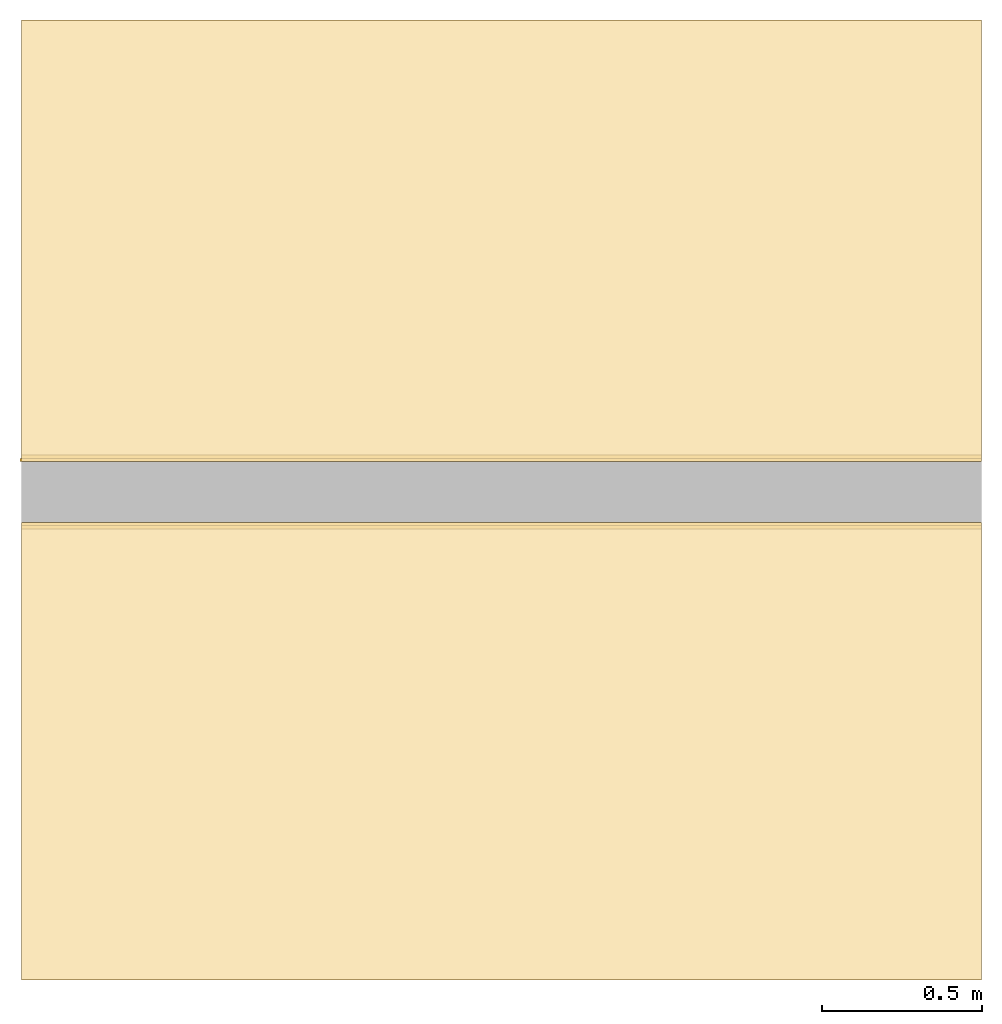
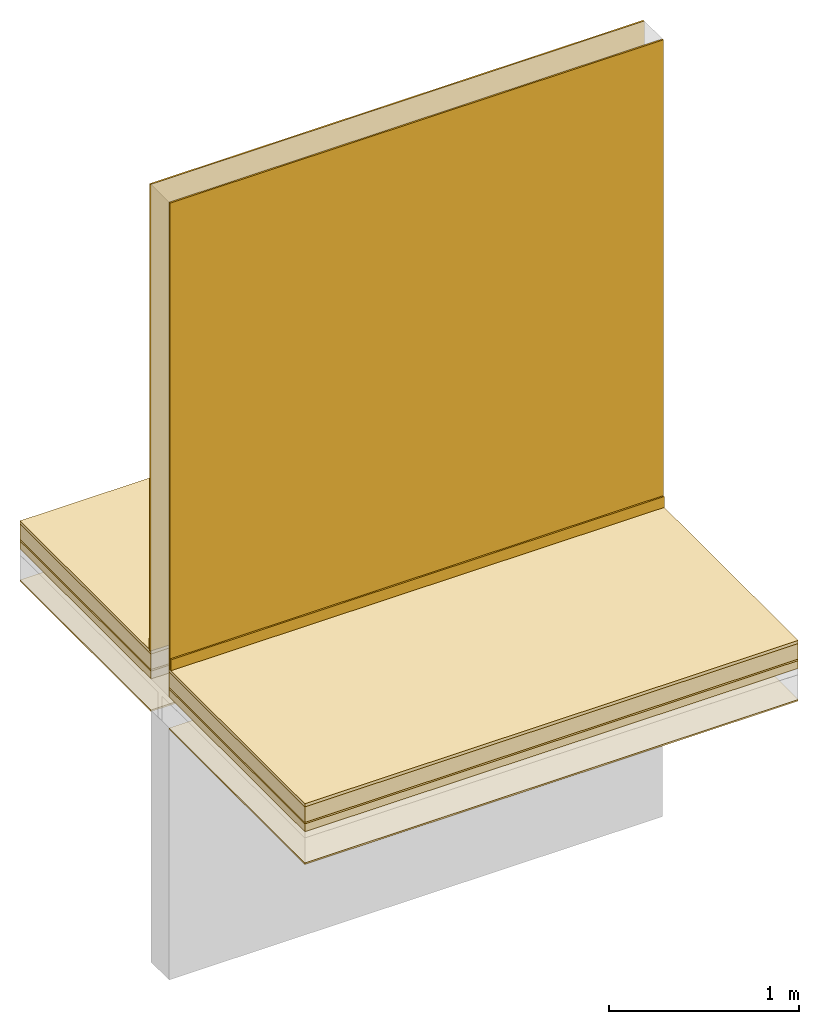
# One storey, part 2 of 2: 14 coverings.
"""IFC4 building model written with IfcOpenShell, lengths in centimetres."""

from ifc_helpers import new_model, si_unit, frame, origin_with_axes, place, context, subcontext, project, spatial, polygons, source, transform, mapped, element, save


model = new_model("IFC4")

# Units and contexts
model_context = context("Model", 3, precision=1e-05, world=origin_with_axes())
plan_context = context("Plan", 2, precision=1e-05, world=origin_with_axes())
body_context = subcontext(model_context, "Body", "Model", "MODEL_VIEW")
ifc_project = project(units=[si_unit("LENGTHUNIT", "METRE", prefix="CENTI"), si_unit("AREAUNIT", "SQUARE_METRE", prefix="CENTI"), si_unit("VOLUMEUNIT", "CUBIC_METRE", prefix="CENTI")], contexts=[model_context, plan_context])

# Site, building, storey
site_placement = place(None, frame((1288.70067596436, 2573.25820922852, 0.0), z_axis=(0.0, 0.0, 1.0), x_axis=(1.0, 0.0, 0.0)))
site = spatial("IfcSite", under=ifc_project, at=site_placement, CompositionType="ELEMENT")
building_placement = place(site_placement, origin_with_axes())
building = spatial("IfcBuilding", under=site, at=building_placement, Name="Default", CompositionType="ELEMENT")
storey_placement = place(building_placement, frame((0.0, 0.0, 1.9145924429198e-09), z_axis=(0.0, 0.0, 1.0), x_axis=(1.0, 0.0, 0.0)))
storey = spatial("IfcBuildingStorey", under=building, at=storey_placement, Name="0", CompositionType="ELEMENT")

# Coverings
shared_shape_1 = source(origin_with_axes(), body_context, "Body", "Tessellation", [
    polygons([(485.905364990234, 254.556915283203, -18.0), (485.905364990234, 254.556915283203, -13.0), (185.905349731445, 254.556915283203, -18.0), (185.905349731445, 254.556915283203, -13.0), (185.905349731445, 111.556922912598, -18.0), (185.905349731445, 111.556922912598, -13.0), (485.905364990234, 111.556922912598, -18.0), (485.905364990234, 111.556922912598, -13.0)], [[[8, 6, 5, 7]], [[2, 8, 7, 1]], [[1, 7, 5, 3]], [[6, 8, 2, 4]], [[4, 2, 1, 3]], [[6, 4, 3, 5]]]),
])
covering_1_placement = place(storey_placement, frame((9.5367431640625e-05, 0.00019073486328125, -1.9145924429198e-09), z_axis=(0.0, 0.0, 1.0), x_axis=(1.0, 0.0, 0.0)))
element("IfcCovering", 1, at=covering_1_placement, inside=storey, Name="Isolation - isolatie", PredefinedType="INSULATION", context=body_context, shape_type="MappedRepresentation", body=[
    mapped(shared_shape_1, transform((0.0, 0.0, 0.0), x_axis=(1.0, 0.0, 0.0), y_axis=(0.0, 1.0, 0.0), z_axis=(0.0, 0.0, 1.0), scale=1.0)),
])
shared_shape_2 = source(origin_with_axes(), body_context, "Body", "Tessellation", [
    polygons([(300.0, -0.5, 0.0), (300.0, -0.5, 300.0), (300.0, 0.5, 0.0), (300.0, 0.5, 300.0), (0.0, 0.5, 0.0), (0.0, 0.5, 300.0), (0.0, -0.5, 0.0), (0.0, -0.5, 300.0)], [[[8, 6, 5, 7]], [[2, 8, 7, 1]], [[1, 7, 5, 3]], [[6, 8, 2, 4]], [[4, 2, 1, 3]], [[6, 4, 3, 5]]]),
])
covering_2_placement = place(storey_placement, frame((485.905456542969, 254.057121276855, -1.9145924429198e-09), z_axis=(0.0, 0.0, 1.0), x_axis=(-1.0, -8.74227765734759e-08, 0.0)))
element("IfcCovering", 2, at=covering_2_placement, inside=storey, Name="Enduit", PredefinedType="CLADDING", context=body_context, shape_type="MappedRepresentation", body=[
    mapped(shared_shape_2, transform((0.0, 0.0, 0.0), x_axis=(1.0, 0.0, 0.0), y_axis=(0.0, 1.0, 0.0), z_axis=(0.0, 0.0, 1.0), scale=1.0)),
])
shared_shape_3 = source(origin_with_axes(), body_context, "Body", "Tessellation", [
    polygons([(485.905364990234, 254.556915283203, -39.0), (485.905364990234, 254.556915283203, -38.0), (185.905349731445, 254.556915283203, -39.0), (185.905349731445, 254.556915283203, -38.0), (185.905349731445, 111.556922912598, -39.0), (185.905349731445, 111.556922912598, -38.0), (485.905364990234, 111.556922912598, -39.0), (485.905364990234, 111.556922912598, -38.0)], [[[8, 6, 5, 7]], [[2, 8, 7, 1]], [[1, 7, 5, 3]], [[6, 8, 2, 4]], [[4, 2, 1, 3]], [[6, 4, 3, 5]]]),
])
covering_3_placement = place(storey_placement, frame((9.5367431640625e-05, 0.00019073486328125, -1.9145924429198e-09), z_axis=(0.0, 0.0, 1.0), x_axis=(1.0, 0.0, 0.0)))
element("IfcCovering", 3, at=covering_3_placement, inside=storey, Name="Enduit", PredefinedType="CEILING", context=body_context, shape_type="MappedRepresentation", body=[
    mapped(shared_shape_3, transform((0.0, 0.0, 0.0), x_axis=(1.0, 0.0, 0.0), y_axis=(0.0, 1.0, 0.0), z_axis=(0.0, 0.0, 1.0), scale=1.0)),
])
shared_shape_4 = source(origin_with_axes(), body_context, "Body", "Tessellation", [
    polygons([(485.905364990234, 411.556915283203, -18.0), (485.905364990234, 411.556915283203, -13.0), (185.905349731445, 411.556915283203, -18.0), (185.905349731445, 411.556915283203, -13.0), (185.905349731445, 273.556915283203, -18.0), (185.905349731445, 273.556915283203, -13.0), (485.905364990234, 273.556915283203, -18.0), (485.905364990234, 273.556915283203, -13.0)], [[[8, 6, 5, 7]], [[2, 8, 7, 1]], [[1, 7, 5, 3]], [[6, 8, 2, 4]], [[4, 2, 1, 3]], [[6, 4, 3, 5]]]),
])
covering_4_placement = place(storey_placement, frame((9.5367431640625e-05, 0.00019073486328125, -1.9145924429198e-09), z_axis=(0.0, 0.0, 1.0), x_axis=(1.0, 0.0, 0.0)))
element("IfcCovering", 4, at=covering_4_placement, inside=storey, Name="Isolation - isolatie", PredefinedType="INSULATION", context=body_context, shape_type="MappedRepresentation", body=[
    mapped(shared_shape_4, transform((0.0, 0.0, 0.0), x_axis=(1.0, 0.0, 0.0), y_axis=(0.0, 1.0, 0.0), z_axis=(0.0, 0.0, 1.0), scale=1.0)),
])
shared_shape_5 = source(origin_with_axes(), body_context, "Body", "Tessellation", [
    polygons([(300.5, -0.5, 0.0), (300.5, -0.5, 300.0), (300.5, 0.5, 0.0), (300.5, 0.5, 300.0), (0.0, 0.5, 0.0), (0.0, 0.5, 300.0), (0.0, -0.5, 0.0), (0.0, -0.5, 300.0)], [[[8, 6, 5, 7]], [[2, 8, 7, 1]], [[1, 7, 5, 3]], [[6, 8, 2, 4]], [[4, 2, 1, 3]], [[6, 4, 3, 5]]]),
])
covering_5_placement = place(storey_placement, frame((485.905456542969, 274.057006835938, -1.9145924429198e-09), z_axis=(0.0, 0.0, 1.0), x_axis=(-1.0, -8.74227765734759e-08, 0.0)))
element("IfcCovering", 5, at=covering_5_placement, inside=storey, Name="Enduit", PredefinedType="CLADDING", context=body_context, shape_type="MappedRepresentation", body=[
    mapped(shared_shape_5, transform((0.0, 0.0, 0.0), x_axis=(1.0, 0.0, 0.0), y_axis=(0.0, 1.0, 0.0), z_axis=(0.0, 0.0, 1.0), scale=1.0)),
])
shared_shape_6 = source(origin_with_axes(), body_context, "Body", "Tessellation", [
    polygons([(485.905364990234, 254.556915283203, -12.0), (485.905364990234, 254.556915283203, -2.0), (185.905349731445, 254.556915283203, -12.0), (185.905349731445, 254.556915283203, -2.0), (185.905349731445, 111.556922912598, -12.0), (185.905349731445, 111.556922912598, -2.0), (485.905364990234, 111.556922912598, -12.0), (485.905364990234, 111.556922912598, -2.0)], [[[8, 6, 5, 7]], [[2, 8, 7, 1]], [[1, 7, 5, 3]], [[6, 8, 2, 4]], [[4, 2, 1, 3]], [[6, 4, 3, 5]]]),
])
covering_6_placement = place(storey_placement, frame((9.5367431640625e-05, 0.00019073486328125, -1.9145924429198e-09), z_axis=(0.0, 0.0, 1.0), x_axis=(1.0, 0.0, 0.0)))
element("IfcCovering", 6, at=covering_6_placement, inside=storey, Name="Chape", PredefinedType="FLOORING", context=body_context, shape_type="MappedRepresentation", body=[
    mapped(shared_shape_6, transform((0.0, 0.0, 0.0), x_axis=(1.0, 0.0, 0.0), y_axis=(0.0, 1.0, 0.0), z_axis=(0.0, 0.0, 1.0), scale=1.0)),
])
shared_shape_7 = source(origin_with_axes(), body_context, "Body", "Tessellation", [
    polygons([(485.905364990234, 411.556915283203, -2.0), (485.905364990234, 411.556915283203, 0.0), (185.905349731445, 411.556915283203, -2.0), (185.905349731445, 411.556915283203, 0.0), (185.905349731445, 273.556915283203, -2.0), (185.905349731445, 273.556915283203, 0.0), (485.905364990234, 273.556915283203, -2.0), (485.905364990234, 273.556915283203, 0.0)], [[[8, 6, 5, 7]], [[2, 8, 7, 1]], [[1, 7, 5, 3]], [[6, 8, 2, 4]], [[4, 2, 1, 3]], [[6, 4, 3, 5]]]),
])
covering_7_placement = place(storey_placement, frame((9.5367431640625e-05, 0.00019073486328125, -1.9145924429198e-09), z_axis=(0.0, 0.0, 1.0), x_axis=(1.0, 0.0, 0.0)))
element("IfcCovering", 7, at=covering_7_placement, inside=storey, PredefinedType="FLOORING", context=body_context, shape_type="MappedRepresentation", body=[
    mapped(shared_shape_7, transform((0.0, 0.0, 0.0), x_axis=(1.0, 0.0, 0.0), y_axis=(0.0, 1.0, 0.0), z_axis=(0.0, 0.0, 1.0), scale=1.0)),
])
shared_shape_8 = source(origin_with_axes(), body_context, "Body", "Tessellation", [
    polygons([(185.905349731445, 252.556915283203, 0.0), (185.905349731445, 252.556915283203, 7.0), (485.905364990234, 252.556915283203, 0.0), (485.905364990234, 252.556915283203, 7.0), (485.905364990234, 253.556915283203, 0.0), (485.905364990234, 253.556915283203, 7.0), (185.905349731445, 253.556915283203, 0.0), (185.905349731445, 253.556915283203, 7.0)], [[[8, 6, 5, 7]], [[2, 8, 7, 1]], [[1, 7, 5, 3]], [[6, 8, 2, 4]], [[4, 2, 1, 3]], [[6, 4, 3, 5]]]),
])
covering_8_placement = place(storey_placement, frame((9.5367431640625e-05, 0.00019073486328125, -1.9145924429198e-09), z_axis=(0.0, 0.0, 1.0), x_axis=(1.0, 0.0, 0.0)))
element("IfcCovering", 8, at=covering_8_placement, inside=storey, PredefinedType="SKIRTINGBOARD", context=body_context, shape_type="MappedRepresentation", body=[
    mapped(shared_shape_8, transform((0.0, 0.0, 0.0), x_axis=(1.0, 0.0, 0.0), y_axis=(0.0, 1.0, 0.0), z_axis=(0.0, 0.0, 1.0), scale=1.0)),
])
shared_shape_9 = source(origin_with_axes(), body_context, "Body", "Tessellation", [
    polygons([(485.905364990234, 411.556915283203, -39.0), (485.905364990234, 411.556915283203, -38.0), (185.905349731445, 411.556915283203, -39.0), (185.905349731445, 411.556915283203, -38.0), (185.905349731445, 273.556915283203, -39.0), (185.905349731445, 273.556915283203, -38.0), (485.905364990234, 273.556915283203, -39.0), (485.905364990234, 273.556915283203, -38.0)], [[[8, 6, 5, 7]], [[2, 8, 7, 1]], [[1, 7, 5, 3]], [[6, 8, 2, 4]], [[4, 2, 1, 3]], [[6, 4, 3, 5]]]),
])
covering_9_placement = place(storey_placement, frame((9.5367431640625e-05, 0.00019073486328125, -1.9145924429198e-09), z_axis=(0.0, 0.0, 1.0), x_axis=(1.0, 0.0, 0.0)))
element("IfcCovering", 9, at=covering_9_placement, inside=storey, Name="Enduit", PredefinedType="CEILING", context=body_context, shape_type="MappedRepresentation", body=[
    mapped(shared_shape_9, transform((0.0, 0.0, 0.0), x_axis=(1.0, 0.0, 0.0), y_axis=(0.0, 1.0, 0.0), z_axis=(0.0, 0.0, 1.0), scale=1.0)),
])
shared_shape_10 = source(origin_with_axes(), body_context, "Body", "Tessellation", [
    polygons([(485.905364990234, 254.556915283203, -2.0), (485.905364990234, 254.556915283203, 0.0), (185.905349731445, 254.556915283203, -2.0), (185.905349731445, 254.556915283203, 0.0), (185.905349731445, 111.556922912598, -2.0), (185.905349731445, 111.556922912598, 0.0), (485.905364990234, 111.556922912598, -2.0), (485.905364990234, 111.556922912598, 0.0)], [[[8, 6, 5, 7]], [[2, 8, 7, 1]], [[1, 7, 5, 3]], [[6, 8, 2, 4]], [[4, 2, 1, 3]], [[6, 4, 3, 5]]]),
])
covering_10_placement = place(storey_placement, frame((9.5367431640625e-05, 0.00019073486328125, -1.9145924429198e-09), z_axis=(0.0, 0.0, 1.0), x_axis=(1.0, 0.0, 0.0)))
element("IfcCovering", 10, at=covering_10_placement, inside=storey, PredefinedType="FLOORING", context=body_context, shape_type="MappedRepresentation", body=[
    mapped(shared_shape_10, transform((0.0, 0.0, 0.0), x_axis=(1.0, 0.0, 0.0), y_axis=(0.0, 1.0, 0.0), z_axis=(0.0, 0.0, 1.0), scale=1.0)),
])
shared_shape_11 = source(origin_with_axes(), body_context, "Body", "Tessellation", [
    polygons([(485.905364990234, 411.556915283203, -12.0), (485.905364990234, 411.556915283203, -2.0), (185.905349731445, 411.556915283203, -12.0), (185.905349731445, 411.556915283203, -2.0), (185.905349731445, 273.556915283203, -12.0), (185.905349731445, 273.556915283203, -2.0), (485.905364990234, 273.556915283203, -12.0), (485.905364990234, 273.556915283203, -2.0)], [[[8, 6, 5, 7]], [[2, 8, 7, 1]], [[1, 7, 5, 3]], [[6, 8, 2, 4]], [[4, 2, 1, 3]], [[6, 4, 3, 5]]]),
])
covering_11_placement = place(storey_placement, frame((9.5367431640625e-05, 0.00019073486328125, -1.9145924429198e-09), z_axis=(0.0, 0.0, 1.0), x_axis=(1.0, 0.0, 0.0)))
element("IfcCovering", 11, at=covering_11_placement, inside=storey, Name="Chape", PredefinedType="FLOORING", context=body_context, shape_type="MappedRepresentation", body=[
    mapped(shared_shape_11, transform((0.0, 0.0, 0.0), x_axis=(1.0, 0.0, 0.0), y_axis=(0.0, 1.0, 0.0), z_axis=(0.0, 0.0, 1.0), scale=1.0)),
])
shared_shape_12 = source(origin_with_axes(), body_context, "Body", "Tessellation", [
    polygons([(185.905349731445, 411.556915283203, -13.0), (185.905349731445, 411.556915283203, -12.0), (185.905349731445, 273.556915283203, -13.0), (185.905349731445, 273.556915283203, -12.0), (485.905364990234, 273.556915283203, -13.0), (485.905364990234, 273.556915283203, -12.0), (485.905364990234, 411.556915283203, -13.0), (485.905364990234, 411.556915283203, -12.0)], [[[8, 6, 5, 7]], [[2, 8, 7, 1]], [[1, 7, 5, 3]], [[6, 8, 2, 4]], [[4, 2, 1, 3]], [[6, 4, 3, 5]]]),
])
covering_12_placement = place(storey_placement, frame((9.5367431640625e-05, 0.00019073486328125, -1.9145924429198e-09), z_axis=(0.0, 0.0, 1.0), x_axis=(1.0, 0.0, 0.0)))
element("IfcCovering", 12, at=covering_12_placement, inside=storey, Name="Pare-vapeur - folie", PredefinedType="MEMBRANE", context=body_context, shape_type="MappedRepresentation", body=[
    mapped(shared_shape_12, transform((0.0, 0.0, 0.0), x_axis=(1.0, 0.0, 0.0), y_axis=(0.0, 1.0, 0.0), z_axis=(0.0, 0.0, 1.0), scale=1.0)),
])
shared_shape_13 = source(origin_with_axes(), body_context, "Body", "Tessellation", [
    polygons([(185.905349731445, 274.556915283203, 0.0), (185.905349731445, 274.556915283203, 7.0), (485.905364990234, 274.556915283203, 0.0), (485.905364990234, 274.556915283203, 7.0), (485.905364990234, 275.556915283203, 0.0), (485.905364990234, 275.556915283203, 7.0), (185.905349731445, 275.556915283203, 0.0), (185.905349731445, 275.556915283203, 7.0)], [[[8, 6, 5, 7]], [[2, 8, 7, 1]], [[1, 7, 5, 3]], [[6, 8, 2, 4]], [[4, 2, 1, 3]], [[6, 4, 3, 5]]]),
])
covering_13_placement = place(storey_placement, frame((9.5367431640625e-05, 0.00019073486328125, -1.9145924429198e-09), z_axis=(0.0, 0.0, 1.0), x_axis=(1.0, 0.0, 0.0)))
element("IfcCovering", 13, at=covering_13_placement, inside=storey, PredefinedType="SKIRTINGBOARD", context=body_context, shape_type="MappedRepresentation", body=[
    mapped(shared_shape_13, transform((0.0, 0.0, 0.0), x_axis=(1.0, 0.0, 0.0), y_axis=(0.0, 1.0, 0.0), z_axis=(0.0, 0.0, 1.0), scale=1.0)),
])
shared_shape_14 = source(origin_with_axes(), body_context, "Body", "Tessellation", [
    polygons([(185.905349731445, 254.556915283203, -13.0), (185.905349731445, 254.556915283203, -12.0), (185.905349731445, 111.556922912598, -13.0), (185.905349731445, 111.556922912598, -12.0), (485.905364990234, 111.556922912598, -13.0), (485.905364990234, 111.556922912598, -12.0), (485.905364990234, 254.556915283203, -13.0), (485.905364990234, 254.556915283203, -12.0)], [[[8, 6, 5, 7]], [[2, 8, 7, 1]], [[1, 7, 5, 3]], [[6, 8, 2, 4]], [[4, 2, 1, 3]], [[6, 4, 3, 5]]]),
])
covering_14_placement = place(storey_placement, frame((9.5367431640625e-05, 0.00019073486328125, -1.9145924429198e-09), z_axis=(0.0, 0.0, 1.0), x_axis=(1.0, 0.0, 0.0)))
element("IfcCovering", 14, at=covering_14_placement, inside=storey, Name="Pare-vapeur - folie", PredefinedType="MEMBRANE", context=body_context, shape_type="MappedRepresentation", body=[
    mapped(shared_shape_14, transform((0.0, 0.0, 0.0), x_axis=(1.0, 0.0, 0.0), y_axis=(0.0, 1.0, 0.0), z_axis=(0.0, 0.0, 1.0), scale=1.0)),
])

save(model, "model.ifc")
